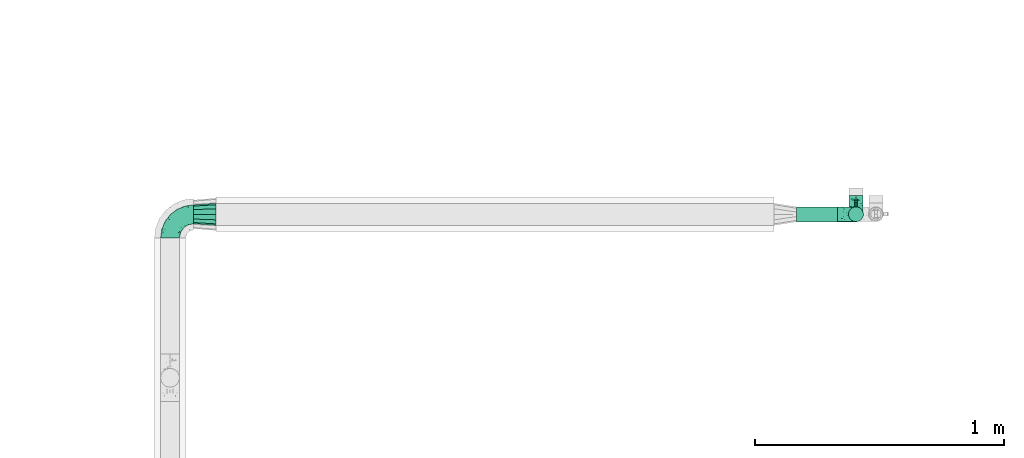
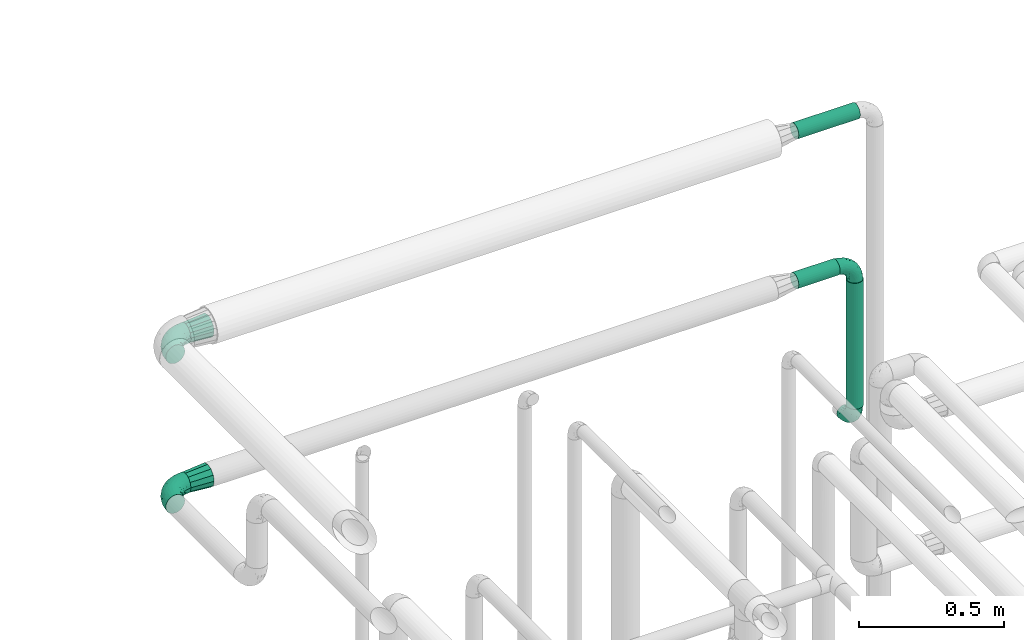
# One storey, part 716 of 824: 6 flow fittings, 3 flow segments.
"""IFC2X3 building model written with IfcOpenShell, lengths in millimetres."""

from ifc_helpers import new_model, entity, si_unit, converted_unit, derived_unit, direction, frame, origin, origin_2d_with_axis, place, context, subcontext, project, spatial, circle, extrude, faceted_brep, source, transform, mapped, material, type_object, type_shapes, element, save


model = new_model("IFC2X3")

# Units and contexts
model_context = context("Model", 3, precision=0.01, world=origin(), true_north=direction((6.12303176911189e-17, 1.0)))
body_context = subcontext(model_context, "Body", "Model", "MODEL_VIEW")
ifc_project = project(units=[si_unit("LENGTHUNIT", "METRE", prefix="MILLI"), si_unit("AREAUNIT", "SQUARE_METRE"), si_unit("VOLUMEUNIT", "CUBIC_METRE"), converted_unit("PLANEANGLEUNIT", "DEGREE", entity("IfcRatioMeasure", 0.0174532925199433), si_unit("PLANEANGLEUNIT", "RADIAN"), dimensions=[0, 0, 0, 0, 0, 0, 0]), si_unit("MASSUNIT", "GRAM", prefix="KILO"), derived_unit("MASSDENSITYUNIT", [(si_unit("MASSUNIT", "GRAM", prefix="KILO"), 1), (si_unit("LENGTHUNIT", "METRE"), -3)]), derived_unit("MOMENTOFINERTIAUNIT", [(si_unit("LENGTHUNIT", "METRE"), 4)]), si_unit("TIMEUNIT", "SECOND"), si_unit("FREQUENCYUNIT", "HERTZ"), si_unit("THERMODYNAMICTEMPERATUREUNIT", "DEGREE_CELSIUS"), derived_unit("THERMALTRANSMITTANCEUNIT", [(si_unit("MASSUNIT", "GRAM", prefix="KILO"), 1), (si_unit("THERMODYNAMICTEMPERATUREUNIT", "KELVIN"), -1), (si_unit("TIMEUNIT", "SECOND"), -3)]), derived_unit("VOLUMETRICFLOWRATEUNIT", [(si_unit("LENGTHUNIT", "METRE"), 3), (si_unit("TIMEUNIT", "SECOND"), -1)]), derived_unit("MASSFLOWRATEUNIT", [(si_unit("MASSUNIT", "GRAM", prefix="KILO"), 1), (si_unit("TIMEUNIT", "SECOND"), -1)]), derived_unit("ROTATIONALFREQUENCYUNIT", [(si_unit("TIMEUNIT", "SECOND"), -1)]), si_unit("ELECTRICCURRENTUNIT", "AMPERE"), si_unit("ELECTRICVOLTAGEUNIT", "VOLT"), si_unit("POWERUNIT", "WATT"), si_unit("FORCEUNIT", "NEWTON", prefix="KILO"), si_unit("ILLUMINANCEUNIT", "LUX"), si_unit("LUMINOUSFLUXUNIT", "LUMEN"), si_unit("LUMINOUSINTENSITYUNIT", "CANDELA"), derived_unit("USERDEFINED", [(si_unit("MASSUNIT", "GRAM", prefix="KILO"), -1), (si_unit("LENGTHUNIT", "METRE"), -2), (si_unit("TIMEUNIT", "SECOND"), 3), (si_unit("LUMINOUSFLUXUNIT", "LUMEN"), 1)]), derived_unit("LINEARVELOCITYUNIT", [(si_unit("LENGTHUNIT", "METRE"), 1), (si_unit("TIMEUNIT", "SECOND"), -1)]), si_unit("PRESSUREUNIT", "PASCAL"), derived_unit("USERDEFINED", [(si_unit("LENGTHUNIT", "METRE"), -2), (si_unit("MASSUNIT", "GRAM", prefix="KILO"), 1), (si_unit("TIMEUNIT", "SECOND"), -2)]), derived_unit("LINEARFORCEUNIT", [(si_unit("MASSUNIT", "GRAM", prefix="KILO"), 1), (si_unit("LENGTHUNIT", "METRE"), 1), (si_unit("TIMEUNIT", "SECOND"), -2), (si_unit("LENGTHUNIT", "METRE"), -1)]), derived_unit("PLANARFORCEUNIT", [(si_unit("MASSUNIT", "GRAM", prefix="KILO"), 1), (si_unit("LENGTHUNIT", "METRE"), 1), (si_unit("TIMEUNIT", "SECOND"), -2), (si_unit("LENGTHUNIT", "METRE"), -2)])], contexts=[model_context])

# Site, building, storey
site_placement = place(None, origin())
site = spatial("IfcSite", under=ifc_project, at=site_placement, CompositionType="ELEMENT")
building_placement = place(site_placement, origin())
building = spatial("IfcBuilding", under=site, at=building_placement, CompositionType="ELEMENT")
storey_placement = place(building_placement, frame((0.0, 0.0, 28200.0)))
storey = spatial("IfcBuildingStorey", under=building, at=storey_placement, CompositionType="ELEMENT", Elevation=28200.0)

# Flow segments
pipe_segment_type = type_object("IfcPipeSegmentType", PredefinedType="NOTDEFINED")
flow_segment_1_placement = place(storey_placement, frame((54488.07, 18668.61, 2918.4)))
element("IfcFlowSegment", 1, at=flow_segment_1_placement, inside=storey, type_object=pipe_segment_type, context=body_context, shape_type="SweptSolid", body=[
    extrude(circle(Radius=30.0, at=origin_2d_with_axis()), frame((0.0, 31.6, 31.6), z_axis=(1.0, 0.0, 0.0), x_axis=(0.0, -1.0, 0.0)), (0.0, 0.0, 1.0), 245.000000000014),
])
flow_segment_2_placement = place(storey_placement, frame((54488.07, 18668.61, 2288.4)))
element("IfcFlowSegment", 2, at=flow_segment_2_placement, inside=storey, type_object=pipe_segment_type, context=body_context, shape_type="SweptSolid", body=[
    extrude(circle(Radius=30.0, at=origin_2d_with_axis()), frame((0.0, 31.6, 31.6), z_axis=(1.0, 0.0, 0.0), x_axis=(0.0, -1.0, 0.0)), (0.0, 0.0, 1.0), 165.000000000014),
])
flow_segment_3_placement = place(storey_placement, frame((54696.47, 18668.61, 1714.93)))
element("IfcFlowSegment", 3, at=flow_segment_3_placement, inside=storey, type_object=pipe_segment_type, context=body_context, shape_type="SweptSolid", body=[
    extrude(circle(Radius=30.0, at=origin_2d_with_axis()), frame((31.6, 31.6, 0.0)), (0.0, 0.0, 1.0), 530.074764587964),
])

# Flow fittings
ifc_material = material()
pipe_fitting_type_1 = type_object("IfcPipeFittingType", PredefinedType="NOTDEFINED", material=ifc_material)
shared_shape_1 = source(origin(), body_context, "Body", "Brep", [
    faceted_brep([(-95.0, 19.02, -32.95), (-95.0, 9.85, -36.75), (-95.0, 0.0, -38.05), (-95.0, -9.85, -36.75), (-95.0, -19.03, -32.95), (-95.0, -26.91, -26.91), (-95.0, -32.95, -19.03), (-95.0, -36.75, -9.85), (-95.0, -38.05, 0.0), (-95.0, -36.75, 9.85), (-95.0, -32.95, 19.02), (-95.0, -26.91, 26.91), (-95.0, -19.03, 32.95), (-95.0, -9.85, 36.75), (-95.0, 0.0, 38.05), (-95.0, 9.85, 36.75), (-95.0, 19.02, 32.95), (-95.0, 26.91, 26.91), (-95.0, 32.95, 19.02), (-95.0, 36.75, 9.85), (-95.0, 38.05, 0.0), (-95.0, 36.75, -9.85), (-95.0, 32.95, -19.03), (-95.0, 26.91, -26.91), (0.0, 95.0, -38.05), (-9.85, 95.0, -36.75), (-19.02, 95.0, -32.95), (-26.91, 95.0, -26.91), (-32.95, 95.0, -19.03), (-36.75, 95.0, -9.85), (-38.05, 95.0, 0.0), (-36.75, 95.0, 9.85), (-32.95, 95.0, 19.02), (-26.91, 95.0, 26.91), (-19.02, 95.0, 32.95), (-9.85, 95.0, 36.75), (0.0, 95.0, 38.05), (9.85, 95.0, 36.75), (19.03, 95.0, 32.95), (26.91, 95.0, 26.91), (32.95, 95.0, 19.02), (36.75, 95.0, 9.85), (38.05, 95.0, 0.0), (36.75, 95.0, -9.85), (32.95, 95.0, -19.03), (26.91, 95.0, -26.91), (19.03, 95.0, -32.95), (9.85, 95.0, -36.75), (-7.99, -4.96, 6.3), (-0.92, 0.92, 0.0), (4.62, 8.1, 8.01), (-76.19, -35.57, 0.0), (-64.32, -32.32, 12.43), (20.51, 62.45, 28.68), (-60.56, -33.52, 0.0), (-70.4, -13.47, 34.42), (-39.61, -5.88, 32.32), (-49.6, 2.07, 37.1), (-70.34, -28.81, 21.71), (14.64, 40.81, 26.5), (5.88, 39.61, 32.32), (3.59, 20.77, 25.31), (-40.45, 68.06, 16.75), (-62.45, -20.51, 28.68), (-44.52, -26.87, 0.0), (-28.47, -20.22, 0.0), (-26.43, -17.83, 8.75), (-76.1, 39.63, 10.76), (-72.74, 37.58, 18.19), (-60.35, 46.18, 14.61), (-13.4, 13.4, 32.12), (-20.77, -3.59, 25.31), (-14.66, 81.47, 35.56), (-6.22, 71.26, 37.92), (-57.5, 42.48, 22.79), (-15.0, 34.74, 37.7), (-27.1, 12.08, 36.05), (-9.2, 28.81, 35.63), (-79.98, 23.7, 30.95), (-73.68, -4.3, 37.48), (-30.74, 21.67, 37.97), (-62.36, 47.59, 6.79), (-72.71, 32.83, 24.69), (-67.42, 7.02, 37.95), (-32.13, 75.27, 24.51), (-43.46, 51.47, 26.26), (-24.98, 73.15, 31.29), (20.59, 41.28, 19.85), (7.79, 16.09, 15.86), (-73.21, 42.39, 0.0), (-54.73, 54.73, 0.0), (-73.44, 15.79, 35.79), (-5.94, 4.32, 20.43), (28.81, 70.34, 21.71), (32.32, 64.32, 12.43), (-53.59, 26.2, 35.09), (-52.02, 19.31, 37.21), (21.38, 33.53, 10.34), (26.87, 44.52, 0.0), (-48.28, 12.14, 38.05), (4.3, 73.68, 37.48), (-44.08, -25.52, 12.79), (-41.28, -20.59, 19.85), (35.57, 76.19, 0.0), (-47.26, 54.3, 20.18), (-47.4, 61.99, 8.58), (-42.39, 73.21, 0.0), (-39.67, 78.86, 7.21), (-45.69, 36.84, 33.11), (-32.83, 50.13, 33.35), (13.47, 70.4, 34.42), (-18.25, 63.73, 36.07), (-40.63, -13.75, 27.22), (-16.63, 46.37, 37.95), (-53.47, 38.79, 28.59), (-26.07, 48.54, 36.15), (-34.51, 34.51, 36.86), (-2.07, 49.6, 37.1), (-22.79, -10.49, 19.23), (-61.73, 28.67, 31.87), (9.65, 14.7, 0.0), (20.22, 28.47, 0.0), (33.52, 60.56, 0.0), (-11.42, -5.44, 13.25), (-14.7, -9.65, 0.0), (-81.47, 14.66, -35.56), (-62.45, -20.51, -28.68), (-71.26, 6.22, -37.92), (-75.27, 32.13, -24.51), (-73.15, 24.98, -31.29), (13.47, 70.4, -34.42), (5.88, 39.61, -32.32), (-2.07, 49.6, -37.1), (-78.86, 39.67, -7.21), (-70.4, -13.47, -34.42), (-39.61, -5.88, -32.32), (-61.99, 47.4, -8.58), (32.32, 64.32, -12.43), (28.81, 70.34, -21.71), (-63.73, 18.25, -36.07), (-50.13, 32.83, -33.35), (4.3, 73.68, -37.48), (-7.02, 67.42, -37.95), (-39.63, 76.1, -10.76), (-46.18, 60.35, -14.61), (-47.59, 62.36, -6.79), (-64.32, -32.32, -12.43), (-26.2, 53.59, -35.09), (-15.79, 73.44, -35.79), (-19.31, 52.02, -37.21), (-37.58, 72.74, -18.19), (-70.34, -28.81, -21.71), (-42.48, 57.5, -22.79), (-38.79, 53.47, -28.59), (-51.47, 43.46, -26.26), (-32.83, 72.71, -24.69), (-46.37, 16.63, -37.95), (-73.68, -4.3, -37.48), (-41.28, -20.59, -19.85), (-44.08, -25.52, -12.79), (13.75, 40.63, -27.22), (20.51, 62.45, -28.68), (-68.06, 40.45, -16.75), (-54.3, 47.26, -20.18), (-12.14, 48.28, -38.05), (-21.67, 30.74, -37.97), (-36.84, 45.69, -33.11), (-11.42, -5.44, -13.25), (7.79, 16.09, -15.86), (4.62, 8.1, -8.01), (-23.7, 79.98, -30.95), (-26.43, -17.83, -8.75), (-7.99, -4.96, -6.3), (-40.81, -14.64, -26.5), (-20.77, -3.59, -25.31), (-34.74, 15.0, -37.7), (-12.08, 27.1, -36.05), (-28.81, 9.2, -35.63), (-22.79, -10.49, -19.23), (21.38, 33.53, -10.34), (20.59, 41.28, -19.85), (-48.54, 26.07, -36.15), (-49.6, 2.07, -37.1), (-13.4, 13.4, -32.12), (3.59, 20.77, -25.31), (-28.67, 61.73, -31.87), (-34.51, 34.51, -36.86), (-5.94, 4.32, -20.43)], [[[0, 1, 2, 3, 4, 5, 6, 7, 8, 9, 10, 11, 12, 13, 14, 15, 16, 17, 18, 19, 20, 21, 22, 23]], [[24, 25, 26, 27, 28, 29, 30, 31, 32, 33, 34, 35, 36, 37, 38, 39, 40, 41, 42, 43, 44, 45, 46, 47]], [[48, 49, 50]], [[51, 52, 9]], [[53, 39, 38]], [[9, 52, 10]], [[54, 52, 51]], [[55, 56, 57]], [[11, 10, 58]], [[59, 60, 61]], [[32, 31, 62]], [[63, 12, 11]], [[63, 55, 12]], [[64, 65, 66]], [[67, 68, 69]], [[70, 56, 71]], [[35, 72, 73]], [[69, 68, 74]], [[75, 76, 77]], [[16, 78, 17]], [[13, 79, 14]], [[76, 75, 80]], [[67, 69, 81]], [[18, 17, 82]], [[14, 79, 83]], [[20, 19, 67]], [[84, 85, 86]], [[87, 61, 88]], [[89, 81, 90]], [[18, 82, 68]], [[15, 91, 16]], [[14, 83, 15]], [[71, 92, 61]], [[17, 78, 82]], [[93, 87, 94]], [[95, 91, 96]], [[97, 98, 94]], [[86, 72, 34]], [[96, 99, 80]], [[37, 36, 100]], [[40, 39, 93]], [[40, 94, 41]], [[64, 66, 101]], [[93, 94, 40]], [[58, 102, 63]], [[94, 103, 41]], [[94, 87, 97]], [[104, 69, 74]], [[34, 33, 86]], [[105, 69, 104]], [[52, 58, 10]], [[106, 107, 30]], [[108, 109, 85]], [[105, 106, 90]], [[53, 110, 60]], [[86, 111, 72]], [[86, 109, 111]], [[33, 84, 86]], [[12, 55, 13]], [[112, 56, 63]], [[110, 38, 37]], [[34, 72, 35]], [[36, 35, 73]], [[111, 113, 73]], [[105, 107, 106]], [[110, 53, 38]], [[74, 114, 85]], [[91, 15, 83]], [[105, 90, 81]], [[107, 62, 31]], [[33, 32, 84]], [[115, 109, 116]], [[111, 115, 113]], [[100, 73, 117]], [[56, 55, 63]], [[79, 55, 57]], [[102, 118, 112]], [[56, 70, 76]], [[100, 110, 37]], [[117, 77, 60]], [[117, 60, 110]], [[60, 70, 61]], [[58, 52, 101]], [[63, 11, 58]], [[39, 53, 93]], [[87, 93, 53]], [[96, 91, 83]], [[78, 91, 119]], [[32, 62, 84]], [[84, 62, 104]], [[86, 85, 109]], [[85, 114, 108]], [[80, 113, 116]], [[117, 73, 113]], [[80, 116, 96]], [[80, 57, 76]], [[71, 112, 118]], [[61, 87, 59]], [[62, 107, 105]], [[97, 120, 121]], [[70, 71, 61]], [[71, 118, 92]], [[73, 100, 36]], [[110, 100, 117]], [[55, 79, 13]], [[83, 79, 57]], [[96, 83, 99]], [[116, 108, 95]], [[50, 97, 88]], [[97, 87, 88]], [[50, 49, 120]], [[122, 94, 98]], [[89, 20, 67]], [[105, 81, 69]], [[89, 67, 81]], [[68, 19, 18]], [[68, 67, 19]], [[74, 68, 82]], [[114, 82, 119]], [[74, 85, 104]], [[82, 114, 74]], [[114, 119, 108]], [[95, 108, 119]], [[116, 109, 108]], [[123, 48, 50]], [[97, 50, 120]], [[123, 50, 88]], [[91, 95, 119]], [[116, 95, 96]], [[84, 104, 85]], [[104, 62, 105]], [[83, 57, 99]], [[57, 80, 99]], [[66, 48, 123]], [[66, 124, 48]], [[118, 66, 123]], [[124, 66, 65]], [[66, 118, 101]], [[54, 64, 52]], [[124, 49, 48]], [[30, 107, 31]], [[91, 78, 16]], [[82, 78, 119]], [[56, 76, 57]], [[77, 76, 70]], [[60, 77, 70]], [[77, 117, 75]], [[117, 113, 75]], [[113, 80, 75]], [[9, 8, 51]], [[103, 94, 122]], [[103, 42, 41]], [[73, 72, 111]], [[113, 115, 116]], [[111, 109, 115]], [[102, 112, 63]], [[71, 56, 112]], [[118, 102, 101]], [[92, 123, 88]], [[123, 92, 118]], [[61, 92, 88]], [[87, 53, 59]], [[60, 59, 53]], [[97, 121, 98]], [[58, 101, 102]], [[64, 101, 52]], [[125, 1, 0]], [[126, 5, 4]], [[2, 1, 127]], [[1, 125, 127]], [[128, 129, 23]], [[130, 131, 132]], [[89, 133, 20]], [[126, 134, 135]], [[136, 89, 90]], [[137, 138, 44]], [[139, 129, 140]], [[24, 141, 142]], [[143, 144, 145]], [[125, 129, 139]], [[6, 146, 7]], [[147, 148, 149]], [[146, 51, 7]], [[143, 150, 144]], [[146, 6, 151]], [[152, 153, 154]], [[126, 4, 134]], [[0, 23, 129]], [[28, 155, 150]], [[43, 42, 103]], [[54, 146, 64]], [[139, 156, 127]], [[157, 3, 2]], [[151, 158, 159]], [[160, 131, 161]], [[22, 21, 162]], [[136, 144, 163]], [[149, 164, 165]], [[24, 142, 25]], [[166, 140, 154]], [[154, 129, 128]], [[143, 30, 29]], [[167, 168, 169]], [[155, 28, 27]], [[26, 170, 27]], [[171, 167, 172]], [[26, 25, 148]], [[27, 170, 155]], [[173, 135, 174]], [[144, 150, 152]], [[175, 176, 177]], [[24, 47, 141]], [[45, 161, 46]], [[148, 25, 142]], [[176, 175, 165]], [[64, 159, 171]], [[138, 45, 44]], [[130, 46, 161]], [[137, 44, 43]], [[178, 159, 158]], [[137, 103, 122]], [[163, 144, 152]], [[136, 133, 89]], [[103, 137, 43]], [[6, 5, 151]], [[178, 158, 173]], [[134, 4, 3]], [[178, 173, 174]], [[137, 98, 179]], [[145, 90, 106]], [[138, 180, 161]], [[46, 130, 47]], [[136, 90, 145]], [[133, 162, 21]], [[23, 22, 128]], [[139, 140, 181]], [[139, 181, 156]], [[157, 127, 182]], [[157, 134, 3]], [[182, 177, 135]], [[182, 135, 134]], [[135, 183, 174]], [[131, 130, 161]], [[141, 130, 132]], [[160, 180, 184]], [[131, 183, 176]], [[5, 126, 151]], [[158, 151, 126]], [[180, 138, 137]], [[161, 45, 138]], [[149, 148, 142]], [[170, 148, 185]], [[22, 162, 128]], [[128, 162, 163]], [[129, 154, 140]], [[154, 153, 166]], [[165, 156, 186]], [[182, 127, 156]], [[165, 186, 149]], [[165, 132, 176]], [[131, 184, 183]], [[187, 167, 178]], [[184, 168, 187]], [[167, 169, 172]], [[184, 180, 168]], [[174, 183, 184]], [[127, 157, 2]], [[134, 157, 182]], [[130, 141, 47]], [[142, 141, 132]], [[149, 142, 164]], [[186, 166, 147]], [[180, 179, 168]], [[169, 179, 120]], [[137, 179, 180]], [[179, 121, 120]], [[106, 30, 143]], [[136, 145, 144]], [[106, 143, 145]], [[150, 29, 28]], [[150, 143, 29]], [[152, 150, 155]], [[153, 155, 185]], [[152, 154, 163]], [[155, 153, 152]], [[153, 185, 166]], [[147, 166, 185]], [[186, 140, 166]], [[169, 120, 49]], [[169, 49, 172]], [[179, 169, 168]], [[148, 147, 185]], [[186, 147, 149]], [[128, 163, 154]], [[163, 162, 136]], [[142, 132, 164]], [[132, 165, 164]], [[171, 124, 65]], [[124, 171, 172]], [[64, 146, 159]], [[171, 159, 178]], [[171, 65, 64]], [[172, 49, 124]], [[162, 133, 136]], [[20, 133, 21]], [[148, 170, 26]], [[155, 170, 185]], [[131, 176, 132]], [[177, 176, 183]], [[135, 177, 183]], [[177, 182, 175]], [[182, 156, 175]], [[156, 165, 175]], [[51, 146, 54]], [[51, 8, 7]], [[129, 125, 0]], [[127, 125, 139]], [[140, 186, 181]], [[156, 181, 186]], [[158, 126, 173]], [[135, 173, 126]], [[187, 178, 174]], [[171, 178, 167]], [[184, 187, 174]], [[167, 187, 168]], [[180, 160, 161]], [[184, 131, 160]], [[98, 137, 122]], [[98, 121, 179]], [[151, 159, 146]]]),
])
type_shapes(pipe_fitting_type_1, [shared_shape_1])
for number, where, z_axis, x_axis in (
    (4, (51968.37, 18700.2, 2950.0), (0.0, 0.0, 1.0), (-1.0, 0.0, 0.0)),
    (5, (51968.1, 18700.2, 2320.0), (0.0, 0.0, 1.0), (-1.0, 0.0, 0.0)),
):
    element("IfcFlowFitting", number, at=place(storey_placement, frame(where, z_axis=z_axis, x_axis=x_axis)), inside=storey, type_object=pipe_fitting_type_1, material=ifc_material, context=body_context, shape_type="MappedRepresentation", body=[
        mapped(shared_shape_1, transform((0.0, 0.0, 0.0), scale=1.0)),
    ])
pipe_fitting_type_2 = type_object("IfcPipeFittingType", PredefinedType="NOTDEFINED", material=ifc_material)
shared_shape_2 = source(origin(), body_context, "Body", "Brep", [
    faceted_brep([(-75.0, 0.0, -28.5), (-75.0, -7.38, -27.53), (-75.0, -14.25, -24.68), (-75.0, -20.15, -20.15), (-75.0, -24.68, -14.25), (-75.0, -27.53, -7.38), (-75.0, -28.5, 0.0), (-75.0, -27.53, 7.38), (-75.0, -24.68, 14.25), (-75.0, -20.15, 20.15), (-75.0, -14.25, 24.68), (-75.0, -7.38, 27.53), (-75.0, 0.0, 28.5), (-75.0, 7.38, 27.53), (-75.0, 14.25, 24.68), (-75.0, 20.15, 20.15), (-75.0, 24.68, 14.25), (-75.0, 27.53, 7.38), (-75.0, 28.5, 0.0), (-75.0, 27.53, -7.38), (-75.0, 24.68, -14.25), (-75.0, 20.15, -20.15), (-75.0, 14.25, -24.68), (-75.0, 7.38, -27.53), (-7.38, 75.0, -27.53), (-14.25, 75.0, -24.68), (-20.15, 75.0, -20.15), (-24.68, 75.0, -14.25), (-27.53, 75.0, -7.38), (-28.5, 75.0, 0.0), (-27.53, 75.0, 7.38), (-24.68, 75.0, 14.25), (-20.15, 75.0, 20.15), (-14.25, 75.0, 24.68), (-7.38, 75.0, 27.53), (0.0, 75.0, 28.5), (7.38, 75.0, 27.53), (14.25, 75.0, 24.68), (20.15, 75.0, 20.15), (24.68, 75.0, 14.25), (27.53, 75.0, 7.38), (28.5, 75.0, 0.0), (27.53, 75.0, -7.38), (24.68, 75.0, -14.25), (20.15, 75.0, -20.15), (14.25, 75.0, -24.68), (7.38, 75.0, -27.53), (0.0, 75.0, -28.5), (-58.34, -3.09, 28.08), (-53.36, 5.47, 28.42), (-60.98, -26.28, 0.0), (-50.38, -23.9, 9.36), (-2.72, 2.72, 0.0), (3.49, 8.33, 5.39), (-8.47, -3.6, 5.43), (-43.02, -23.43, 0.0), (9.86, 31.5, 19.95), (3.58, 31.64, 24.39), (0.78, 15.8, 19.09), (-55.53, -21.42, 16.31), (-41.02, 15.05, 27.84), (-38.36, 9.63, 28.5), (-24.63, 17.21, 28.45), (14.9, 48.57, 21.5), (-48.57, -14.9, 21.5), (-55.48, -9.89, 25.8), (-22.48, -12.99, 7.59), (-28.59, -16.08, 0.0), (-14.16, -8.73, 0.0), (-38.26, 22.79, 26.22), (-58.0, 11.98, 26.79), (-31.64, -3.58, 24.39), (-39.5, 2.0, 27.82), (-30.52, 53.58, 12.47), (-11.07, 64.24, 26.62), (-4.85, 56.28, 28.4), (-62.79, 17.89, 23.17), (-57.59, 24.67, 18.42), (-50.35, 32.08, 12.72), (-63.79, 27.28, 11.71), (-11.91, 27.95, 28.26), (-21.91, 10.04, 27.08), (-7.9, 23.21, 26.78), (8.73, 14.16, 0.0), (-61.42, 30.11, 4.72), (-44.0, 30.05, 19.91), (-2.0, 39.5, 27.82), (9.89, 55.48, 25.8), (-11.33, 11.33, 24.21), (-17.5, -1.61, 19.5), (13.94, 30.82, 14.87), (19.0, 37.09, 10.84), (21.42, 55.53, 16.31), (3.09, 58.34, 28.08), (-15.17, -4.71, 14.28), (-39.06, -21.55, 5.21), (-35.82, -18.71, 10.31), (23.9, 50.38, 9.36), (-30.11, 61.42, 4.72), (-38.06, 40.7, 14.41), (-33.21, 40.38, 19.56), (26.28, 60.98, 0.0), (-30.82, -13.94, 14.87), (-18.89, 57.68, 23.4), (-24.2, 59.35, 18.31), (-41.53, 41.53, 6.86), (-34.73, 51.75, 0.0), (-51.75, 34.73, 0.0), (-25.37, 39.36, 24.88), (-36.07, 30.61, 23.61), (-32.31, -9.26, 20.83), (-14.02, 50.19, 26.99), (-13.14, 36.54, 28.42), (16.08, 28.59, 0.0), (12.99, 22.48, 7.59), (20.38, 36.25, 5.56), (23.43, 43.02, 0.0), (-48.14, 22.05, 23.83), (-20.29, 38.18, 27.03), (-27.1, 27.1, 27.56), (6.41, 16.13, 12.8), (-4.24, 6.02, 15.65), (-3.26, 3.26, 10.59), (-64.24, 11.07, -26.62), (-48.57, -14.9, -21.5), (-56.28, 4.85, -28.4), (-59.35, 24.2, -18.31), (-57.68, 18.89, -23.4), (9.89, 55.48, -25.8), (3.58, 31.64, -24.39), (-2.0, 39.5, -27.82), (-61.42, 30.11, -4.72), (-30.11, 61.42, -4.72), (-41.53, 41.53, -6.86), (23.9, 50.38, -9.36), (21.42, 55.53, -16.31), (-50.19, 14.02, -26.99), (-39.36, 25.37, -24.88), (3.09, 58.34, -28.08), (-5.47, 53.36, -28.42), (-11.98, 58.0, -26.79), (-50.38, -23.9, -9.36), (13.94, 30.82, -14.87), (14.9, 48.57, -21.5), (-22.79, 38.26, -26.22), (-15.05, 41.02, -27.84), (-55.53, -21.42, -16.31), (-9.63, 38.36, -28.5), (-17.21, 24.63, -28.45), (-22.48, -12.99, -7.59), (-30.61, 36.07, -23.61), (-58.34, -3.09, -28.08), (-37.09, -19.0, -10.84), (-30.82, -13.94, -14.87), (21.55, 39.06, -5.21), (18.71, 35.82, -10.31), (-23.21, 7.9, -26.78), (-39.5, 2.0, -27.82), (-27.95, 11.91, -28.26), (-36.25, -20.38, -5.56), (-24.67, 57.59, -18.42), (3.6, 8.47, -5.43), (-8.33, -3.49, -5.39), (-17.89, 62.79, -23.17), (-32.46, -10.54, -19.76), (-31.64, -3.58, -24.39), (-17.5, -1.61, -19.5), (-10.04, 21.91, -27.08), (-32.08, 50.35, -12.72), (-27.28, 63.79, -11.71), (-30.05, 44.0, -19.91), (-40.38, 33.21, -19.56), (-55.48, -9.89, -25.8), (-53.58, 30.52, -12.47), (12.99, 22.48, -7.59), (9.13, 31.36, -20.52), (-15.17, -4.71, -14.28), (-4.24, 6.02, -15.65), (-3.26, 3.26, -10.59), (-40.7, 38.06, -14.41), (-36.54, 13.14, -28.42), (-22.05, 48.14, -23.83), (-38.18, 20.29, -27.03), (-11.33, 11.33, -24.21), (0.78, 15.8, -19.09), (-27.1, 27.1, -27.56), (6.41, 16.13, -12.8)], [[[0, 1, 2, 3, 4, 5, 6, 7, 8, 9, 10, 11, 12, 13, 14, 15, 16, 17, 18, 19, 20, 21, 22, 23]], [[24, 25, 26, 27, 28, 29, 30, 31, 32, 33, 34, 35, 36, 37, 38, 39, 40, 41, 42, 43, 44, 45, 46, 47]], [[12, 48, 49]], [[50, 51, 7]], [[52, 53, 54]], [[7, 51, 8]], [[55, 51, 50]], [[56, 57, 58]], [[9, 8, 59]], [[60, 61, 62]], [[63, 38, 37]], [[64, 10, 9]], [[64, 65, 10]], [[66, 67, 68]], [[69, 70, 60]], [[65, 71, 72]], [[31, 30, 73]], [[13, 70, 14]], [[34, 74, 75]], [[14, 76, 15]], [[11, 48, 12]], [[77, 78, 79]], [[80, 81, 82]], [[15, 77, 16]], [[52, 83, 53]], [[18, 17, 84]], [[79, 17, 16]], [[12, 49, 13]], [[77, 85, 78]], [[82, 86, 80]], [[37, 87, 63]], [[88, 71, 89]], [[90, 91, 92]], [[39, 38, 92]], [[87, 37, 36]], [[35, 93, 36]], [[94, 66, 54]], [[35, 34, 75]], [[95, 96, 51]], [[39, 97, 40]], [[98, 30, 29]], [[92, 97, 39]], [[99, 100, 73]], [[97, 101, 40]], [[59, 102, 64]], [[63, 87, 57]], [[100, 103, 104]], [[105, 106, 107]], [[51, 59, 8]], [[106, 98, 29]], [[69, 108, 109]], [[84, 105, 107]], [[89, 71, 110]], [[104, 103, 32]], [[33, 32, 103]], [[108, 111, 103]], [[111, 112, 75]], [[74, 103, 111]], [[74, 34, 33]], [[18, 84, 107]], [[10, 65, 11]], [[113, 114, 83]], [[115, 116, 97]], [[70, 13, 49]], [[76, 77, 15]], [[117, 109, 85]], [[32, 31, 104]], [[111, 108, 118]], [[111, 118, 112]], [[93, 75, 86]], [[71, 65, 64]], [[48, 65, 72]], [[110, 102, 89]], [[71, 88, 81]], [[93, 87, 36]], [[86, 82, 57]], [[86, 57, 87]], [[57, 88, 58]], [[59, 51, 96]], [[64, 9, 59]], [[38, 63, 92]], [[90, 92, 63]], [[60, 70, 49]], [[76, 70, 117]], [[103, 100, 108]], [[69, 109, 117]], [[62, 112, 119]], [[86, 75, 112]], [[62, 119, 60]], [[62, 72, 81]], [[89, 58, 88]], [[52, 54, 68]], [[31, 73, 104]], [[100, 104, 73]], [[102, 94, 89]], [[120, 58, 121]], [[89, 94, 121]], [[58, 90, 56]], [[75, 93, 35]], [[87, 93, 86]], [[65, 48, 11]], [[49, 48, 72]], [[60, 49, 61]], [[69, 60, 119]], [[99, 105, 78]], [[98, 105, 73]], [[7, 6, 50]], [[101, 97, 116]], [[101, 41, 40]], [[96, 95, 66]], [[96, 66, 102]], [[91, 114, 115]], [[115, 114, 113]], [[114, 90, 120]], [[79, 84, 17]], [[105, 84, 78]], [[105, 98, 106]], [[73, 30, 98]], [[70, 76, 14]], [[77, 76, 117]], [[49, 72, 61]], [[72, 62, 61]], [[108, 69, 119]], [[70, 69, 117]], [[108, 100, 109]], [[85, 109, 100]], [[85, 100, 99]], [[117, 85, 77]], [[71, 81, 72]], [[82, 81, 88]], [[57, 82, 88]], [[86, 112, 80]], [[112, 62, 80]], [[81, 80, 62]], [[77, 79, 16]], [[84, 79, 78]], [[103, 74, 33]], [[75, 74, 111]], [[105, 99, 73]], [[85, 99, 78]], [[108, 119, 118]], [[112, 118, 119]], [[122, 54, 53]], [[83, 114, 53]], [[120, 53, 114]], [[94, 54, 122]], [[66, 68, 54]], [[71, 64, 110]], [[102, 110, 64]], [[66, 94, 102]], [[121, 94, 122]], [[120, 121, 122]], [[89, 121, 58]], [[120, 122, 53]], [[58, 120, 90]], [[90, 63, 56]], [[57, 56, 63]], [[59, 96, 102]], [[51, 55, 95]], [[55, 67, 95]], [[66, 95, 67]], [[116, 115, 113]], [[91, 115, 97]], [[92, 91, 97]], [[114, 91, 90]], [[123, 23, 22]], [[124, 3, 2]], [[0, 23, 125]], [[23, 123, 125]], [[126, 127, 21]], [[128, 129, 130]], [[107, 131, 18]], [[29, 132, 106]], [[133, 107, 106]], [[134, 135, 43]], [[136, 127, 137]], [[47, 138, 139]], [[140, 24, 139]], [[123, 127, 136]], [[4, 141, 5]], [[135, 142, 143]], [[141, 50, 5]], [[144, 140, 145]], [[141, 4, 146]], [[145, 147, 148]], [[149, 68, 67]], [[22, 21, 127]], [[144, 137, 150]], [[42, 41, 101]], [[151, 1, 0]], [[152, 146, 153]], [[154, 155, 134]], [[156, 157, 158]], [[132, 133, 106]], [[159, 55, 141]], [[29, 28, 132]], [[47, 139, 24]], [[26, 160, 27]], [[52, 161, 83]], [[68, 162, 52]], [[26, 25, 163]], [[140, 25, 24]], [[164, 165, 166]], [[47, 46, 138]], [[158, 167, 156]], [[160, 168, 169]], [[168, 160, 170]], [[171, 127, 126]], [[45, 143, 128]], [[172, 124, 2]], [[131, 19, 18]], [[20, 19, 173]], [[113, 83, 174]], [[44, 43, 135]], [[143, 45, 44]], [[134, 42, 101]], [[175, 129, 143]], [[134, 101, 116]], [[172, 2, 1]], [[124, 172, 165]], [[42, 134, 43]], [[45, 128, 46]], [[176, 177, 178]], [[179, 171, 173]], [[169, 28, 27]], [[4, 3, 146]], [[136, 180, 125]], [[163, 160, 26]], [[181, 150, 170]], [[21, 20, 126]], [[136, 137, 182]], [[136, 182, 180]], [[151, 125, 157]], [[151, 172, 1]], [[157, 156, 165]], [[157, 165, 172]], [[165, 183, 166]], [[129, 128, 143]], [[138, 128, 130]], [[175, 142, 184]], [[129, 183, 167]], [[3, 124, 146]], [[146, 124, 164]], [[135, 134, 155]], [[143, 44, 135]], [[145, 140, 139]], [[163, 140, 181]], [[127, 171, 137]], [[144, 150, 181]], [[148, 180, 185]], [[157, 125, 180]], [[148, 185, 145]], [[148, 130, 167]], [[52, 162, 161]], [[153, 164, 166]], [[20, 173, 126]], [[171, 126, 173]], [[184, 166, 183]], [[176, 153, 166]], [[129, 184, 183]], [[177, 186, 178]], [[125, 151, 0]], [[172, 151, 157]], [[128, 138, 46]], [[139, 138, 130]], [[145, 139, 147]], [[144, 145, 185]], [[179, 133, 168]], [[131, 133, 173]], [[50, 141, 55]], [[50, 6, 5]], [[152, 149, 159]], [[159, 149, 67]], [[149, 153, 176]], [[186, 174, 161]], [[155, 154, 174]], [[155, 174, 142]], [[133, 131, 107]], [[173, 19, 131]], [[169, 132, 28]], [[133, 132, 168]], [[140, 163, 25]], [[160, 163, 181]], [[139, 130, 147]], [[130, 148, 147]], [[137, 144, 185]], [[140, 144, 181]], [[137, 171, 150]], [[170, 150, 171]], [[170, 171, 179]], [[181, 170, 160]], [[129, 167, 130]], [[156, 167, 183]], [[165, 156, 183]], [[157, 180, 158]], [[180, 148, 158]], [[167, 158, 148]], [[160, 169, 27]], [[132, 169, 168]], [[127, 123, 22]], [[125, 123, 136]], [[133, 179, 173]], [[170, 179, 168]], [[137, 185, 182]], [[180, 182, 185]], [[149, 176, 162]], [[149, 162, 68]], [[162, 178, 161]], [[186, 161, 178]], [[174, 83, 161]], [[146, 164, 153]], [[165, 164, 124]], [[177, 166, 184]], [[176, 178, 162]], [[166, 177, 176]], [[186, 184, 142]], [[184, 186, 177]], [[174, 186, 142]], [[142, 175, 143]], [[184, 129, 175]], [[55, 159, 67]], [[152, 159, 141]], [[146, 152, 141]], [[149, 152, 153]], [[135, 155, 142]], [[134, 116, 154]], [[116, 113, 154]], [[174, 154, 113]]]),
])
type_shapes(pipe_fitting_type_2, [shared_shape_2])
for number, where, z_axis, x_axis in (
    (6, (54728.07, 18700.2, 2320.0), (0.0, 1.0, 0.0), (1.0, 0.0, 0.0)),
    (7, (54728.07, 18700.2, 1639.93), (1.0, 0.0, 0.0), (0.0, 0.0, -1.0)),
):
    element("IfcFlowFitting", number, at=place(storey_placement, frame(where, z_axis=z_axis, x_axis=x_axis)), inside=storey, type_object=pipe_fitting_type_2, material=ifc_material, context=body_context, shape_type="MappedRepresentation", body=[
        mapped(shared_shape_2, transform((0.0, 0.0, 0.0), scale=1.0)),
    ])
pipe_fitting_type_3 = type_object("IfcPipeFittingType", PredefinedType="NOTDEFINED", material=ifc_material)
shared_shape_3 = source(origin(), body_context, "Body", "Brep", [
    faceted_brep([(89.0, -44.45, 0.0), (89.0, -41.96, -9.31), (89.0, -38.49, -22.22), (89.0, -30.36, -30.36), (89.0, -22.23, -38.49), (89.0, -11.11, -41.47), (89.0, 0.0, -44.45), (89.0, 11.11, -41.47), (89.0, 22.22, -38.49), (89.0, 30.36, -30.36), (89.0, 38.49, -22.22), (89.0, 41.96, -9.31), (89.0, 44.45, 0.0), (89.0, 41.96, 9.31), (89.0, 38.49, 22.23), (89.0, 30.36, 30.36), (89.0, 22.22, 38.49), (89.0, 11.11, 41.47), (89.0, 0.0, 44.45), (89.0, -11.11, 41.47), (89.0, -22.23, 38.49), (89.0, -30.36, 30.36), (89.0, -38.49, 22.23), (89.0, -41.96, 9.31), (0.0, 38.05, 0.0), (0.0, 35.5, -9.51), (0.0, 32.95, -19.02), (0.0, 25.99, -25.99), (0.0, 19.02, -32.95), (0.0, 9.51, -35.5), (0.0, 0.0, -38.05), (0.0, -9.51, -35.5), (0.0, -19.03, -32.95), (0.0, -25.99, -25.99), (0.0, -32.95, -19.02), (0.0, -35.5, -9.51), (0.0, -38.05, 0.0), (0.0, -35.5, 9.51), (0.0, -32.95, 19.03), (0.0, -25.99, 25.99), (0.0, -19.03, 32.95), (0.0, -9.51, 35.5), (0.0, 0.0, 38.05), (0.0, 9.51, 35.5), (0.0, 19.03, 32.95), (0.0, 25.99, 25.99), (0.0, 32.95, 19.03), (0.0, 35.5, 9.51)], [[[0, 1, 2, 3, 4, 5, 6, 7, 8, 9, 10, 11, 12, 13, 14, 15, 16, 17, 18, 19, 20, 21, 22, 23]], [[24, 25, 26, 27, 28, 29, 30, 31, 32, 33, 34, 35, 36, 37, 38, 39, 40, 41, 42, 43, 44, 45, 46, 47]], [[2, 1, 0, 36, 35, 34]], [[28, 8, 7, 6, 30, 29]], [[32, 4, 3, 2, 34, 33]], [[5, 4, 32, 31, 30, 6]], [[10, 26, 25, 24, 12, 11]], [[9, 8, 28, 27, 26, 10]], [[14, 13, 12, 24, 47, 46]], [[40, 20, 19, 18, 42, 41]], [[44, 16, 15, 14, 46, 45]], [[17, 16, 44, 43, 42, 18]], [[22, 38, 37, 36, 0, 23]], [[21, 20, 40, 39, 38, 22]]]),
])
type_shapes(pipe_fitting_type_3, [shared_shape_3])
for number, where in (
    (8, (52063.37, 18700.2, 2950.0)),
    (9, (52063.1, 18700.2, 2320.0)),
):
    element("IfcFlowFitting", number, at=place(storey_placement, frame(where)), inside=storey, type_object=pipe_fitting_type_3, material=ifc_material, context=body_context, shape_type="MappedRepresentation", body=[
        mapped(shared_shape_3, transform((0.0, 0.0, 0.0), scale=1.0)),
    ])

save(model, "model.ifc")
